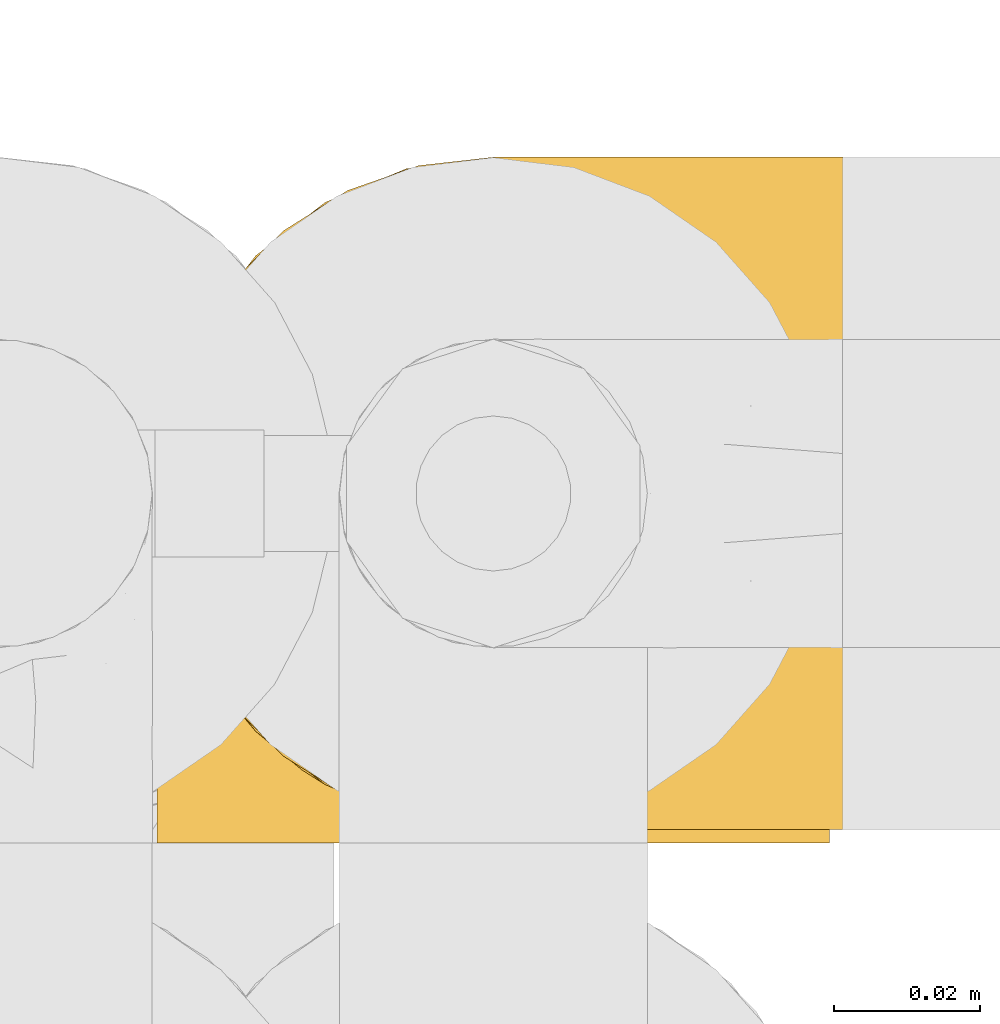
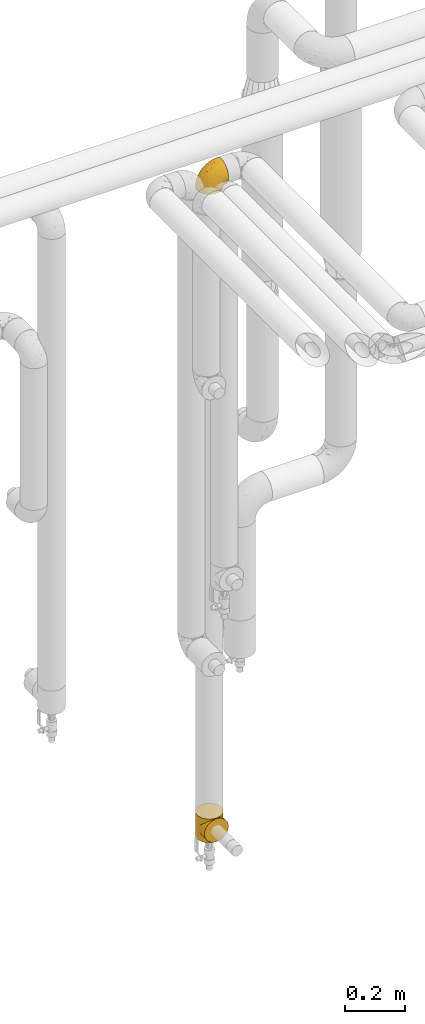
# One storey, part 310 of 827: 2 coverings.
"""IFC2X3 building model written with IfcOpenShell, lengths in millimetres."""

from ifc_helpers import new_model, entity, si_unit, converted_unit, derived_unit, direction, frame, origin, place, context, subcontext, project, spatial, faceted_brep, element, save


model = new_model("IFC2X3")

# Units and contexts
model_context = context("Model", 3, precision=0.01, world=origin(), true_north=direction((6.12303176911189e-17, 1.0)))
body_context = subcontext(model_context, "Body", "Model", "MODEL_VIEW")
ifc_project = project(units=[si_unit("LENGTHUNIT", "METRE", prefix="MILLI"), si_unit("AREAUNIT", "SQUARE_METRE"), si_unit("VOLUMEUNIT", "CUBIC_METRE"), converted_unit("PLANEANGLEUNIT", "DEGREE", entity("IfcRatioMeasure", 0.0174532925199433), si_unit("PLANEANGLEUNIT", "RADIAN"), dimensions=[0, 0, 0, 0, 0, 0, 0]), si_unit("MASSUNIT", "GRAM", prefix="KILO"), derived_unit("MASSDENSITYUNIT", [(si_unit("MASSUNIT", "GRAM", prefix="KILO"), 1), (si_unit("LENGTHUNIT", "METRE"), -3)]), derived_unit("MOMENTOFINERTIAUNIT", [(si_unit("LENGTHUNIT", "METRE"), 4)]), si_unit("TIMEUNIT", "SECOND"), si_unit("FREQUENCYUNIT", "HERTZ"), si_unit("THERMODYNAMICTEMPERATUREUNIT", "DEGREE_CELSIUS"), derived_unit("THERMALTRANSMITTANCEUNIT", [(si_unit("MASSUNIT", "GRAM", prefix="KILO"), 1), (si_unit("THERMODYNAMICTEMPERATUREUNIT", "KELVIN"), -1), (si_unit("TIMEUNIT", "SECOND"), -3)]), derived_unit("VOLUMETRICFLOWRATEUNIT", [(si_unit("LENGTHUNIT", "METRE"), 3), (si_unit("TIMEUNIT", "SECOND"), -1)]), derived_unit("MASSFLOWRATEUNIT", [(si_unit("MASSUNIT", "GRAM", prefix="KILO"), 1), (si_unit("TIMEUNIT", "SECOND"), -1)]), derived_unit("ROTATIONALFREQUENCYUNIT", [(si_unit("TIMEUNIT", "SECOND"), -1)]), si_unit("ELECTRICCURRENTUNIT", "AMPERE"), si_unit("ELECTRICVOLTAGEUNIT", "VOLT"), si_unit("POWERUNIT", "WATT"), si_unit("FORCEUNIT", "NEWTON", prefix="KILO"), si_unit("ILLUMINANCEUNIT", "LUX"), si_unit("LUMINOUSFLUXUNIT", "LUMEN"), si_unit("LUMINOUSINTENSITYUNIT", "CANDELA"), derived_unit("USERDEFINED", [(si_unit("MASSUNIT", "GRAM", prefix="KILO"), -1), (si_unit("LENGTHUNIT", "METRE"), -2), (si_unit("TIMEUNIT", "SECOND"), 3), (si_unit("LUMINOUSFLUXUNIT", "LUMEN"), 1)]), derived_unit("LINEARVELOCITYUNIT", [(si_unit("LENGTHUNIT", "METRE"), 1), (si_unit("TIMEUNIT", "SECOND"), -1)]), si_unit("PRESSUREUNIT", "PASCAL"), derived_unit("USERDEFINED", [(si_unit("LENGTHUNIT", "METRE"), -2), (si_unit("MASSUNIT", "GRAM", prefix="KILO"), 1), (si_unit("TIMEUNIT", "SECOND"), -2)]), derived_unit("LINEARFORCEUNIT", [(si_unit("MASSUNIT", "GRAM", prefix="KILO"), 1), (si_unit("LENGTHUNIT", "METRE"), 1), (si_unit("TIMEUNIT", "SECOND"), -2), (si_unit("LENGTHUNIT", "METRE"), -1)]), derived_unit("PLANARFORCEUNIT", [(si_unit("MASSUNIT", "GRAM", prefix="KILO"), 1), (si_unit("LENGTHUNIT", "METRE"), 1), (si_unit("TIMEUNIT", "SECOND"), -2), (si_unit("LENGTHUNIT", "METRE"), -2)])], contexts=[model_context])

# Site, building, storey
site_placement = place(None, origin())
site = spatial("IfcSite", under=ifc_project, at=site_placement, CompositionType="ELEMENT")
building_placement = place(site_placement, origin())
building = spatial("IfcBuilding", under=site, at=building_placement, CompositionType="ELEMENT")
storey_placement = place(building_placement, frame((0.0, 0.0, 28200.0)))
storey = spatial("IfcBuildingStorey", under=building, at=storey_placement, Name="08", CompositionType="ELEMENT", Elevation=28200.0)

# Coverings
covering_1_placement = place(storey_placement, frame((30677.28, 18393.41, 2950.4)))
element("IfcCovering", 1, at=covering_1_placement, inside=storey, Name=":ADSK_", ObjectType=":ADSK_", PredefinedType="INSULATION", context=body_context, shape_type="Brep", body=[
    faceted_brep([(18.98, 11.68, 1.6), (11.67, 19.0, 1.6), (6.17, 27.76, 1.6), (2.75, 37.52, 1.6), (1.6, 47.8, 1.6), (2.75, 58.08, 1.6), (6.17, 67.85, 1.6), (11.68, 76.61, 1.6), (19.0, 83.92, 1.6), (27.76, 89.42, 1.6), (37.52, 92.84, 1.6), (47.8, 94.0, 1.6), (51.94, 93.53, 1.6), (55.01, 93.18, 1.6), (58.08, 92.84, 1.6), (62.96, 91.13, 1.6), (67.85, 89.42, 1.6), (72.23, 86.66, 1.6), (76.61, 83.91, 1.6), (80.26, 80.25, 1.6), (83.92, 76.59, 1.6), (89.42, 67.83, 1.6), (91.13, 62.95, 1.6), (92.84, 58.07, 1.6), (94.0, 47.8, 1.6), (92.84, 37.51, 1.6), (91.13, 32.63, 1.6), (89.42, 27.74, 1.6), (83.91, 18.98, 1.6), (80.25, 15.33, 1.6), (76.59, 11.67, 1.6), (72.21, 8.92, 1.6), (67.83, 6.17, 1.6), (62.95, 4.46, 1.6), (58.07, 2.75, 1.6), (55.0, 2.41, 1.6), (51.94, 2.06, 1.6), (47.8, 1.6, 1.6), (37.51, 2.75, 1.6), (27.74, 6.17, 1.6), (95.8, 47.8, 3.4), (95.8, 59.75, 4.97), (95.8, 70.9, 9.58), (95.8, 75.68, 13.26), (95.8, 80.46, 16.93), (95.8, 84.13, 21.71), (95.8, 87.81, 26.5), (95.8, 90.11, 32.07), (95.8, 92.42, 37.64), (95.8, 92.9, 41.25), (95.8, 93.17, 43.34), (95.8, 93.45, 45.42), (95.8, 94.0, 49.6), (95.8, 92.42, 61.55), (95.8, 87.81, 72.7), (95.8, 80.46, 82.26), (95.8, 70.9, 89.61), (95.8, 59.75, 94.22), (95.8, 47.8, 95.8), (95.8, 35.84, 94.22), (95.8, 24.7, 89.61), (95.8, 15.13, 82.26), (95.8, 7.78, 72.7), (95.8, 3.17, 61.55), (95.8, 1.6, 49.6), (95.8, 2.14, 45.42), (95.8, 2.69, 41.25), (95.8, 3.17, 37.64), (95.8, 5.48, 32.07), (95.8, 7.78, 26.5), (95.8, 11.46, 21.71), (95.8, 15.13, 16.93), (95.8, 19.91, 13.26), (95.8, 24.7, 9.58), (95.8, 35.84, 4.97), (60.58, 23.61, 81.55), (74.11, 31.99, 90.4), (51.59, 35.87, 83.0), (66.69, 47.8, 91.18), (76.19, 40.43, 93.13), (84.43, 47.8, 94.0), (31.2, 31.83, 66.19), (42.88, 23.37, 70.92), (79.41, 21.41, 85.95), (60.7, 3.07, 49.74), (61.85, 1.6, 35.54), (65.75, 1.6, 38.14), (69.64, 1.6, 40.74), (73.53, 1.6, 43.34), (77.43, 1.6, 45.94), (74.59, 13.45, 77.59), (54.72, 15.25, 71.17), (64.18, 8.07, 65.81), (37.94, 16.0, 59.03), (25.89, 17.34, 45.85), (34.73, 10.58, 45.79), (42.89, 5.34, 41.42), (49.83, 2.39, 34.51), (48.58, 8.36, 56.04), (22.41, 10.04, 15.15), (78.69, 2.59, 56.51), (81.64, 6.28, 68.39), (6.22, 34.28, 23.33), (12.11, 38.73, 42.86), (14.81, 27.25, 39.42), (21.61, 29.88, 53.58), (22.41, 38.6, 59.17), (30.12, 23.44, 59.06), (10.01, 25.25, 22.63), (15.36, 17.23, 20.55), (3.39, 47.8, 12.96), (19.59, 47.8, 56.96), (30.01, 47.8, 67.38), (41.19, 2.53, 18.72), (48.54, 1.6, 5.33), (49.28, 1.6, 9.07), (49.82, 1.6, 11.79), (50.37, 1.6, 14.51), (50.91, 1.6, 17.24), (51.45, 1.6, 19.96), (31.61, 5.71, 21.03), (80.15, 1.6, 46.48), (82.88, 1.6, 47.03), (85.6, 1.6, 47.57), (88.32, 1.6, 48.11), (90.19, 1.6, 48.48), (92.06, 1.6, 48.85), (6.21, 47.8, 30.7), (54.05, 1.6, 23.86), (56.65, 1.6, 27.75), (59.25, 1.6, 31.64), (24.66, 11.89, 31.26), (40.43, 47.8, 77.8), (35.17, 39.69, 72.75), (12.9, 47.8, 43.83), (53.56, 47.8, 84.49), (85.34, 13.84, 14.58), (78.44, 9.16, 16.17), (84.37, 15.79, 10.82), (89.05, 25.75, 4.64), (82.76, 16.09, 7.71), (86.31, 7.51, 25.13), (83.73, 3.99, 32.66), (77.31, 2.66, 34.94), (87.78, 3.16, 36.76), (87.91, 2.35, 40.48), (81.29, 2.23, 39.25), (93.97, 38.35, 3.69), (70.76, 6.18, 13.99), (63.67, 2.7, 21.85), (62.62, 2.93, 17.93), (90.64, 16.01, 15.11), (84.08, 9.08, 21.14), (76.28, 9.3, 12.7), (77.45, 11.68, 7.21), (88.72, 4.65, 32.27), (71.28, 3.65, 25.68), (68.09, 3.61, 22.18), (91.07, 12.8, 18.79), (57.47, 2.43, 10.12), (70.34, 6.83, 9.47), (91.35, 21.65, 10.45), (62.99, 3.7, 11.29), (94.52, 47.8, 2.87), (76.47, 3.37, 31.16), (69.96, 7.03, 6.31), (89.86, 7.87, 25.62), (78.94, 7.26, 21.18), (73.51, 3.41, 28.81), (89.62, 23.81, 7.45), (84.09, 86.5, 21.14), (86.3, 88.08, 25.13), (91.06, 82.79, 18.79), (88.32, 94.0, 48.11), (92.06, 94.0, 48.85), (82.88, 94.0, 47.03), (85.6, 94.0, 47.57), (93.97, 57.24, 3.69), (89.63, 71.76, 7.44), (50.37, 94.0, 14.51), (49.82, 94.0, 11.79), (48.54, 94.0, 5.33), (49.28, 94.0, 9.07), (82.77, 79.49, 7.71), (70.36, 88.75, 9.47), (77.31, 92.93, 34.94), (76.47, 92.22, 31.16), (69.64, 94.0, 40.74), (65.75, 94.0, 38.14), (87.78, 92.43, 36.76), (87.91, 93.24, 40.48), (89.06, 69.82, 4.63), (90.65, 79.57, 15.11), (85.35, 81.74, 14.58), (73.53, 94.0, 43.34), (77.43, 94.0, 45.94), (81.29, 93.36, 39.25), (77.46, 83.9, 7.21), (76.29, 86.28, 12.69), (57.47, 93.16, 10.14), (63.71, 92.88, 21.81), (68.11, 91.98, 22.19), (70.77, 89.41, 14.0), (71.31, 91.93, 25.69), (78.46, 86.42, 16.17), (69.52, 88.82, 6.66), (62.64, 92.66, 17.92), (91.35, 73.93, 10.45), (59.25, 94.0, 31.64), (84.6, 79.5, 10.64), (62.98, 91.89, 11.31), (51.45, 94.0, 19.96), (54.05, 94.0, 23.86), (56.65, 94.0, 27.75), (83.73, 91.6, 32.66), (80.15, 94.0, 46.48), (88.72, 90.94, 32.27), (61.85, 94.0, 35.54), (73.56, 92.16, 28.77), (78.96, 88.32, 21.17), (91.36, 86.13, 23.36), (50.91, 94.0, 17.24), (62.87, 93.2, 47.58), (76.19, 55.16, 93.13), (73.57, 82.02, 77.44), (56.07, 84.29, 66.78), (49.77, 76.94, 71.68), (44.73, 68.33, 74.96), (60.58, 71.98, 81.55), (47.64, 92.52, 36.7), (78.32, 92.9, 56.9), (51.59, 59.72, 83.0), (74.11, 63.6, 90.4), (76.04, 88.89, 67.83), (79.41, 74.18, 85.95), (14.82, 68.35, 39.41), (6.22, 61.33, 23.33), (12.12, 56.86, 42.87), (23.51, 68.62, 53.92), (31.2, 63.76, 66.19), (34.96, 72.19, 64.12), (33.86, 88.69, 33.13), (38.94, 92.19, 23.1), (30.23, 89.75, 16.98), (35.17, 55.9, 72.75), (15.85, 77.99, 23.77), (22.59, 85.21, 18.41), (21.56, 74.99, 43.7), (55.94, 90.23, 54.53), (20.67, 59.86, 55.72), (9.19, 70.75, 17.73), (25.79, 81.72, 38.98), (41.16, 86.53, 50.28), (37.95, 79.6, 59.02)], [[[0, 1, 2, 3, 4, 5, 6, 7, 8, 9, 10, 11, 12, 13, 14, 15, 16, 17, 18, 19, 20, 21, 22, 23, 24, 25, 26, 27, 28, 29, 30, 31, 32, 33, 34, 35, 36, 37, 38, 39]], [[40, 41, 42, 43, 44, 45, 46, 47, 48, 49, 50, 51, 52, 53, 54, 55, 56, 57, 58, 59, 60, 61, 62, 63, 64, 65, 66, 67, 68, 69, 70, 71, 72, 73, 74]], [[75, 76, 77]], [[78, 79, 80]], [[77, 81, 82]], [[76, 75, 83]], [[84, 85, 86, 87, 88, 89]], [[90, 91, 92]], [[76, 60, 59]], [[93, 94, 95]], [[90, 62, 61]], [[83, 61, 60]], [[96, 97, 84]], [[98, 93, 95]], [[0, 39, 99]], [[100, 84, 89]], [[62, 101, 63]], [[2, 102, 3]], [[92, 84, 100]], [[103, 102, 104]], [[103, 105, 106]], [[93, 107, 94]], [[1, 108, 2]], [[92, 101, 90]], [[108, 1, 109]], [[102, 110, 3]], [[93, 82, 107]], [[102, 108, 104]], [[111, 106, 112]], [[109, 0, 99]], [[113, 37, 114, 115, 116, 117, 118, 119]], [[120, 38, 113]], [[100, 89, 121, 122, 123, 124, 125, 126, 64]], [[127, 102, 103]], [[97, 119, 128, 129, 130, 85]], [[99, 120, 131]], [[132, 133, 77]], [[59, 80, 79]], [[1, 0, 109]], [[98, 84, 92]], [[94, 109, 131]], [[120, 39, 38]], [[93, 91, 82]], [[104, 94, 105]], [[97, 113, 119]], [[95, 120, 96]], [[83, 90, 61]], [[91, 93, 98]], [[64, 63, 100]], [[100, 63, 101]], [[77, 76, 79]], [[133, 106, 81]], [[84, 97, 85]], [[113, 96, 120]], [[113, 97, 96]], [[37, 113, 38]], [[110, 102, 127]], [[110, 4, 3]], [[103, 111, 134, 127]], [[90, 75, 91]], [[82, 81, 107]], [[91, 75, 82]], [[77, 82, 75]], [[76, 83, 60]], [[90, 83, 75]], [[105, 107, 81]], [[94, 131, 95]], [[105, 94, 107]], [[109, 94, 104]], [[120, 95, 131]], [[98, 95, 96]], [[84, 98, 96]], [[98, 92, 91]], [[106, 105, 81]], [[103, 104, 105]], [[112, 106, 133]], [[103, 106, 111]], [[112, 133, 132]], [[81, 77, 133]], [[77, 78, 135, 132]], [[120, 99, 39]], [[109, 99, 131]], [[59, 58, 80]], [[59, 79, 76]], [[90, 101, 62]], [[100, 101, 92]], [[2, 108, 102]], [[109, 104, 108]], [[78, 77, 79]], [[136, 137, 138]], [[27, 139, 140]], [[141, 142, 143]], [[144, 145, 121]], [[146, 89, 88]], [[147, 139, 25]], [[148, 149, 150]], [[136, 151, 152]], [[147, 40, 74]], [[24, 147, 25]], [[140, 153, 154]], [[33, 116, 34]], [[73, 72, 151]], [[114, 37, 36, 35, 34, 116, 115]], [[146, 155, 144]], [[156, 85, 130]], [[157, 149, 148]], [[151, 158, 152]], [[117, 33, 159]], [[29, 154, 160]], [[161, 74, 73]], [[162, 128, 119]], [[66, 65, 64, 126, 125, 124, 123, 122, 67]], [[163, 147, 24]], [[27, 140, 28]], [[149, 129, 150]], [[139, 27, 26, 25]], [[68, 144, 69]], [[129, 128, 150]], [[164, 87, 86]], [[130, 129, 149]], [[122, 145, 67]], [[154, 153, 148]], [[162, 119, 159]], [[165, 30, 160]], [[150, 160, 148]], [[128, 162, 150]], [[30, 165, 31]], [[145, 144, 68]], [[89, 146, 144]], [[87, 164, 143]], [[166, 155, 142]], [[88, 87, 143]], [[162, 160, 150]], [[160, 30, 29]], [[154, 29, 28]], [[140, 154, 28]], [[160, 154, 148]], [[140, 137, 153]], [[157, 148, 153]], [[156, 130, 157]], [[153, 137, 157]], [[157, 137, 156]], [[167, 137, 136]], [[168, 85, 156]], [[152, 168, 167]], [[167, 168, 156]], [[164, 152, 141]], [[71, 158, 72]], [[152, 167, 136]], [[88, 142, 146]], [[144, 155, 69]], [[146, 142, 155]], [[70, 166, 71]], [[142, 141, 166]], [[70, 69, 155]], [[141, 158, 71]], [[161, 73, 151]], [[138, 137, 140]], [[161, 136, 169]], [[136, 161, 151]], [[74, 161, 169]], [[152, 158, 141]], [[151, 72, 158]], [[168, 152, 164]], [[137, 167, 156]], [[164, 86, 168]], [[85, 168, 86]], [[116, 33, 117]], [[130, 149, 157]], [[67, 145, 68]], [[121, 89, 144]], [[145, 122, 121]], [[40, 147, 163]], [[169, 147, 74]], [[159, 33, 32]], [[162, 159, 32]], [[159, 119, 118, 117]], [[139, 147, 169]], [[139, 169, 138]], [[162, 32, 31]], [[141, 143, 164]], [[88, 143, 142]], [[71, 166, 141]], [[155, 166, 70]], [[139, 138, 140]], [[169, 136, 138]], [[160, 162, 165]], [[162, 31, 165]], [[170, 171, 172]], [[173, 174, 52, 51, 50, 49, 48, 175, 176]], [[177, 178, 41]], [[179, 15, 180]], [[12, 11, 181, 182, 180, 14, 13]], [[183, 21, 20]], [[19, 18, 184]], [[185, 186, 187]], [[186, 188, 187]], [[43, 172, 44]], [[189, 190, 47]], [[23, 22, 21, 191]], [[170, 192, 193]], [[40, 163, 177]], [[194, 195, 196]], [[24, 23, 177]], [[197, 198, 183]], [[199, 15, 179]], [[47, 46, 189]], [[200, 201, 202]], [[201, 203, 204]], [[205, 206, 184]], [[207, 41, 178]], [[16, 15, 199]], [[14, 180, 15]], [[202, 201, 198]], [[208, 201, 200]], [[163, 24, 177]], [[48, 47, 190]], [[196, 195, 189]], [[197, 184, 202]], [[204, 193, 209]], [[210, 211, 212]], [[206, 212, 213]], [[205, 17, 210]], [[184, 206, 202]], [[210, 212, 206]], [[185, 194, 214]], [[189, 215, 190]], [[216, 45, 214]], [[186, 171, 170]], [[189, 216, 196]], [[197, 20, 19]], [[194, 185, 187]], [[197, 183, 20]], [[184, 197, 19]], [[197, 202, 198]], [[206, 200, 202]], [[204, 183, 198]], [[201, 208, 203]], [[203, 208, 217]], [[204, 198, 201]], [[217, 188, 218]], [[193, 219, 170]], [[171, 186, 185]], [[170, 218, 186]], [[170, 219, 218]], [[42, 207, 192]], [[171, 220, 172]], [[216, 189, 46]], [[214, 194, 196]], [[44, 220, 45]], [[214, 196, 216]], [[216, 46, 45]], [[214, 45, 220]], [[192, 43, 42]], [[204, 203, 219]], [[207, 193, 192]], [[209, 193, 178]], [[41, 207, 42]], [[193, 207, 178]], [[43, 192, 172]], [[170, 172, 192]], [[204, 219, 193]], [[219, 203, 218]], [[217, 218, 203]], [[188, 186, 218]], [[206, 213, 200]], [[208, 200, 213]], [[199, 210, 16]], [[215, 189, 195]], [[215, 175, 190]], [[175, 48, 190]], [[199, 179, 221, 211]], [[210, 199, 211]], [[23, 191, 177]], [[40, 177, 41]], [[178, 177, 191]], [[21, 183, 191]], [[209, 191, 183]], [[205, 18, 17]], [[17, 16, 210]], [[171, 185, 214]], [[172, 220, 44]], [[214, 220, 171]], [[191, 209, 178]], [[204, 209, 183]], [[206, 205, 210]], [[18, 205, 184]], [[222, 195, 194, 187, 188, 217]], [[57, 223, 80]], [[224, 225, 226]], [[226, 227, 228]], [[229, 217, 208, 213, 212, 211]], [[230, 52, 174, 173, 176, 175, 215, 195]], [[231, 232, 228]], [[231, 78, 223]], [[223, 57, 232]], [[224, 233, 225]], [[233, 54, 53]], [[234, 232, 56]], [[56, 55, 234]], [[234, 224, 228]], [[235, 236, 237]], [[224, 55, 54]], [[238, 239, 240]], [[52, 230, 53]], [[241, 242, 243]], [[227, 244, 231]], [[11, 10, 242]], [[236, 6, 5]], [[7, 245, 8]], [[8, 246, 9]], [[238, 247, 235]], [[222, 229, 248]], [[242, 211, 221, 179, 180, 182, 181, 11]], [[233, 53, 230]], [[111, 112, 249]], [[250, 6, 236]], [[246, 251, 241]], [[6, 250, 7]], [[127, 236, 110]], [[248, 229, 252]], [[246, 8, 245]], [[235, 245, 250]], [[236, 5, 110]], [[235, 249, 238]], [[237, 236, 127]], [[243, 9, 246]], [[252, 229, 241]], [[56, 232, 57]], [[222, 230, 195]], [[225, 248, 252]], [[248, 233, 230]], [[54, 233, 224]], [[231, 228, 227]], [[244, 132, 231]], [[248, 225, 233]], [[226, 225, 253]], [[235, 250, 236]], [[245, 7, 250]], [[251, 246, 245]], [[243, 246, 241]], [[247, 245, 235]], [[252, 251, 253]], [[229, 222, 217]], [[230, 222, 248]], [[5, 4, 110]], [[237, 127, 134, 111]], [[238, 249, 239]], [[224, 234, 55]], [[232, 234, 228]], [[242, 241, 229]], [[10, 9, 243]], [[211, 242, 229]], [[10, 243, 242]], [[80, 223, 78]], [[80, 58, 57]], [[231, 223, 232]], [[227, 240, 239]], [[224, 226, 228]], [[240, 226, 253]], [[227, 239, 244]], [[226, 240, 227]], [[251, 247, 253]], [[240, 253, 247]], [[249, 235, 237]], [[237, 111, 249]], [[112, 132, 244]], [[112, 244, 249]], [[78, 231, 132, 135]], [[249, 244, 239]], [[247, 238, 240]], [[245, 247, 251]], [[251, 252, 241]], [[225, 252, 253]]]),
])
covering_2_placement = place(storey_placement, frame((30677.28, 18393.2, 327.0)))
element("IfcCovering", 2, at=covering_2_placement, inside=storey, Name=":ADSK_", ObjectType=":ADSK_", PredefinedType="INSULATION", context=body_context, shape_type="Brep", body=[
    faceted_brep([(2.11, 41.09, 41.09), (1.6, 48.0, 0.0), (3.17, 36.04, 0.0), (25.36, 7.85, 7.85), (27.48, 6.84, 0.0), (29.21, 5.7, 5.7), (7.78, 24.9, 0.0), (6.34, 27.6, 27.6), (10.15, 21.22, 21.22), (15.13, 15.33, 0.0), (24.7, 7.99, 0.0), (35.84, 3.37, 0.0), (37.01, 3.18, 3.18), (35.9, 3.54, 3.54), (33.67, 4.26, 4.26), (1.6, 48.0, 48.0), (2.11, 41.09, 54.91), (1.6, 48.0, 96.0), (38.13, 2.82, 2.82), (37.33, 3.18, 0.0), (38.83, 2.98, 0.0), (3.68, 34.26, 34.26), (44.06, 2.29, 0.0), (44.81, 2.19, 0.0), (44.17, 2.18, 2.18), (43.31, 2.39, 0.0), (21.52, 10.0, 10.0), (19.91, 11.66, 0.0), (33.05, 4.53, 0.0), (31.44, 4.98, 4.98), (30.27, 5.68, 0.0), (46.3, 2.0, 0.0), (46.59, 1.93, 1.93), (45.38, 2.06, 2.06), (42.96, 2.31, 2.31), (40.32, 2.78, 0.0), (41.82, 2.59, 0.0), (40.54, 2.57, 2.57), (15.18, 15.28, 15.28), (39.33, 2.7, 2.7), (41.75, 2.44, 2.44), (47.8, 1.8, 0.0), (47.8, 1.8, 1.8), (47.8, 1.8, 96.0), (46.59, 1.93, 94.07), (47.8, 1.8, 94.2), (45.55, 2.1, 0.0), (61.93, 4.27, 4.27), (59.75, 3.37, 0.0), (62.54, 4.53, 0.0), (52.28, 2.39, 0.0), (53.77, 2.59, 0.0), (52.64, 2.31, 2.31), (59.7, 3.55, 3.55), (58.59, 3.19, 3.19), (65.32, 5.68, 0.0), (66.38, 5.7, 5.7), (64.16, 4.98, 4.98), (57.48, 2.83, 2.83), (56.76, 2.98, 0.0), (58.26, 3.18, 0.0), (68.11, 6.84, 0.0), (70.9, 7.99, 0.0), (70.23, 7.85, 7.85), (74.07, 10.0, 10.0), (75.68, 11.66, 0.0), (80.41, 15.27, 15.27), (50.22, 2.06, 2.06), (49.29, 2.0, 0.0), (50.04, 2.1, 0.0), (50.78, 2.19, 0.0), (80.46, 15.33, 0.0), (85.44, 21.21, 21.21), (87.81, 24.9, 0.0), (55.06, 2.57, 2.57), (53.85, 2.44, 2.44), (89.25, 27.6, 27.6), (92.42, 36.04, 0.0), (56.27, 2.7, 2.7), (55.27, 2.78, 0.0), (93.48, 41.09, 41.09), (94.0, 48.0, 0.0), (91.9, 34.26, 34.26), (94.0, 48.0, 48.0), (93.48, 41.09, 54.91), (94.0, 48.0, 96.0), (49.01, 1.93, 1.93), (51.43, 2.18, 2.18), (51.53, 2.29, 0.0), (49.01, 1.93, 94.07), (70.9, 88.01, 96.0), (59.75, 92.63, 96.0), (47.8, 94.2, 96.0), (35.84, 92.63, 96.0), (24.7, 88.01, 96.0), (15.13, 80.67, 96.0), (7.78, 71.1, 96.0), (3.17, 59.96, 96.0), (3.17, 36.04, 96.0), (7.78, 24.9, 96.0), (15.13, 15.33, 96.0), (19.91, 11.66, 96.0), (24.7, 7.99, 96.0), (27.48, 6.84, 96.0), (30.27, 5.68, 96.0), (33.05, 4.53, 96.0), (35.84, 3.37, 96.0), (37.33, 3.18, 96.0), (38.83, 2.98, 96.0), (40.32, 2.78, 96.0), (41.82, 2.59, 96.0), (43.31, 2.39, 96.0), (44.06, 2.29, 96.0), (44.81, 2.19, 96.0), (45.55, 2.1, 96.0), (46.3, 2.0, 96.0), (49.29, 2.0, 96.0), (50.04, 2.1, 96.0), (50.78, 2.19, 96.0), (51.53, 2.29, 96.0), (52.28, 2.39, 96.0), (53.77, 2.59, 96.0), (55.27, 2.78, 96.0), (56.76, 2.98, 96.0), (58.26, 3.18, 96.0), (59.75, 3.37, 96.0), (62.54, 4.53, 96.0), (65.32, 5.68, 96.0), (68.11, 6.84, 96.0), (70.9, 7.99, 96.0), (75.68, 11.66, 96.0), (80.46, 15.33, 96.0), (87.81, 24.9, 96.0), (92.42, 36.04, 96.0), (92.42, 59.96, 96.0), (87.81, 71.1, 96.0), (80.46, 80.67, 96.0), (3.17, 59.96, 0.0), (7.78, 71.1, 0.0), (15.13, 80.67, 0.0), (24.7, 88.01, 0.0), (35.84, 92.63, 0.0), (47.8, 94.2, 0.0), (59.75, 92.63, 0.0), (70.9, 88.01, 0.0), (80.46, 80.67, 0.0), (87.81, 71.1, 0.0), (92.42, 59.96, 0.0), (33.67, 4.26, 91.74), (35.9, 3.54, 92.46), (37.01, 3.18, 92.82), (3.68, 34.26, 61.74), (6.34, 27.6, 68.4), (29.21, 5.7, 90.3), (39.33, 2.7, 93.3), (40.54, 2.57, 93.43), (10.15, 21.22, 74.78), (21.52, 10.0, 86.0), (25.36, 7.85, 88.15), (15.18, 15.28, 80.72), (31.44, 4.98, 91.02), (38.13, 2.82, 93.18), (45.38, 2.06, 93.94), (41.75, 2.44, 93.56), (42.96, 2.31, 93.69), (44.17, 2.18, 93.82), (66.38, 5.7, 90.3), (64.16, 4.98, 91.02), (74.07, 10.0, 86.0), (55.06, 2.57, 93.43), (80.41, 15.27, 80.73), (70.23, 7.85, 88.15), (56.27, 2.7, 93.3), (57.48, 2.83, 93.17), (51.43, 2.18, 93.82), (52.64, 2.31, 93.69), (61.93, 4.27, 91.73), (58.59, 3.19, 92.81), (59.7, 3.55, 92.45), (89.25, 27.6, 68.4), (91.9, 34.26, 61.74), (85.44, 21.21, 74.79), (53.85, 2.44, 93.56), (50.22, 2.06, 93.94), (1.6, 0.0, 48.0), (3.17, 0.0, 36.04), (7.78, 0.0, 24.9), (15.13, 0.0, 15.33), (19.91, 0.0, 11.66), (24.7, 0.0, 7.99), (27.48, 0.0, 6.84), (30.27, 0.0, 5.68), (33.05, 0.0, 4.53), (35.84, 0.0, 3.37), (37.33, 0.0, 3.18), (38.83, 0.0, 2.98), (40.32, 0.0, 2.78), (41.82, 0.0, 2.59), (43.31, 0.0, 2.39), (44.06, 0.0, 2.29), (44.81, 0.0, 2.19), (45.55, 0.0, 2.1), (46.3, 0.0, 2.0), (47.8, 0.0, 1.8), (49.29, 0.0, 2.0), (50.04, 0.0, 2.1), (50.78, 0.0, 2.19), (51.53, 0.0, 2.29), (52.28, 0.0, 2.39), (53.77, 0.0, 2.59), (55.27, 0.0, 2.78), (56.76, 0.0, 2.98), (58.26, 0.0, 3.18), (59.75, 0.0, 3.37), (62.54, 0.0, 4.53), (65.32, 0.0, 5.68), (68.11, 0.0, 6.84), (70.9, 0.0, 7.99), (75.68, 0.0, 11.66), (80.46, 0.0, 15.33), (87.81, 0.0, 24.9), (92.42, 0.0, 36.04), (94.0, 0.0, 48.0), (92.42, 0.0, 59.96), (87.81, 0.0, 71.1), (80.46, 0.0, 80.67), (75.68, 0.0, 84.34), (70.9, 0.0, 88.01), (68.11, 0.0, 89.16), (65.32, 0.0, 90.32), (62.54, 0.0, 91.47), (59.75, 0.0, 92.63), (58.26, 0.0, 92.82), (56.76, 0.0, 93.02), (55.27, 0.0, 93.22), (53.77, 0.0, 93.41), (52.28, 0.0, 93.61), (51.53, 0.0, 93.71), (50.78, 0.0, 93.81), (50.04, 0.0, 93.9), (49.29, 0.0, 94.0), (47.8, 0.0, 94.2), (46.3, 0.0, 94.0), (45.55, 0.0, 93.9), (44.81, 0.0, 93.81), (44.06, 0.0, 93.71), (43.31, 0.0, 93.61), (41.82, 0.0, 93.41), (40.32, 0.0, 93.22), (38.83, 0.0, 93.02), (37.33, 0.0, 92.82), (35.84, 0.0, 92.63), (33.05, 0.0, 91.47), (30.27, 0.0, 90.32), (27.48, 0.0, 89.16), (24.7, 0.0, 88.01), (19.91, 0.0, 84.34), (15.13, 0.0, 80.67), (7.78, 0.0, 71.1), (3.17, 0.0, 59.96)], [[[0, 1, 2]], [[3, 4, 5]], [[2, 6, 7]], [[8, 6, 9]], [[4, 3, 10]], [[8, 7, 6]], [[11, 12, 13, 14]], [[0, 15, 1]], [[15, 16, 17]], [[18, 19, 20]], [[7, 21, 2]], [[0, 2, 21]], [[19, 18, 12]], [[12, 11, 19]], [[22, 23, 24, 25]], [[26, 27, 10]], [[28, 29, 30]], [[28, 11, 14]], [[31, 32, 33]], [[29, 28, 14]], [[34, 25, 24]], [[35, 36, 37]], [[38, 9, 27]], [[38, 27, 26]], [[5, 30, 29]], [[20, 39, 18]], [[5, 4, 30]], [[26, 10, 3]], [[35, 39, 20]], [[9, 38, 8]], [[36, 34, 40, 37]], [[34, 36, 25]], [[39, 35, 37]], [[32, 41, 42]], [[43, 44, 45]], [[23, 33, 24]], [[33, 23, 46, 31]], [[41, 32, 31]], [[47, 48, 49]], [[50, 51, 52]], [[48, 47, 53, 54]], [[55, 56, 57]], [[58, 59, 60]], [[61, 62, 63]], [[49, 57, 47]], [[58, 60, 54]], [[64, 62, 65]], [[66, 64, 65]], [[61, 63, 56]], [[67, 68, 69, 70]], [[65, 71, 66]], [[62, 64, 63]], [[72, 71, 73]], [[51, 74, 75, 52]], [[76, 73, 77]], [[78, 79, 59]], [[59, 58, 78]], [[80, 77, 81]], [[79, 78, 74]], [[76, 72, 73]], [[80, 82, 77]], [[83, 80, 81]], [[84, 83, 85]], [[56, 55, 61]], [[76, 77, 82]], [[57, 49, 55]], [[48, 54, 60]], [[71, 72, 66]], [[74, 51, 79]], [[86, 41, 68]], [[87, 50, 52]], [[70, 87, 67]], [[50, 87, 70, 88]], [[41, 86, 42]], [[89, 43, 45]], [[68, 67, 86]], [[90, 91, 92, 93, 94, 95, 96, 97, 17, 98, 99, 100, 101, 102, 103, 104, 105, 106, 107, 108, 109, 110, 111, 112, 113, 114, 115, 43, 116, 117, 118, 119, 120, 121, 122, 123, 124, 125, 126, 127, 128, 129, 130, 131, 132, 133, 85, 134, 135, 136]], [[1, 137, 138, 139, 140, 141, 142, 143, 144, 145, 146, 147, 81, 77, 73, 71, 65, 62, 61, 55, 49, 48, 60, 59, 79, 51, 50, 88, 70, 69, 68, 41, 31, 46, 23, 22, 25, 36, 35, 20, 19, 11, 28, 30, 4, 10, 27, 9, 6, 2]], [[140, 139, 95, 94]], [[92, 142, 141, 93]], [[141, 140, 94, 93]], [[96, 138, 137, 97]], [[1, 15, 17, 97, 137]], [[95, 139, 138, 96]], [[106, 148, 149, 150]], [[151, 152, 98]], [[153, 104, 103]], [[148, 106, 105]], [[16, 151, 98]], [[109, 154, 155]], [[17, 16, 98]], [[99, 156, 100]], [[99, 98, 152]], [[156, 99, 152]], [[102, 157, 158]], [[106, 150, 107]], [[155, 110, 109]], [[157, 101, 159]], [[105, 160, 148]], [[161, 107, 150]], [[162, 115, 114, 113]], [[157, 102, 101]], [[153, 103, 158]], [[104, 153, 160]], [[159, 101, 100]], [[102, 158, 103]], [[108, 161, 154]], [[110, 155, 163, 164]], [[164, 111, 110]], [[161, 108, 107]], [[160, 105, 104]], [[159, 100, 156]], [[154, 109, 108]], [[44, 43, 115]], [[165, 111, 164]], [[113, 165, 162]], [[111, 165, 113, 112]], [[115, 162, 44]], [[166, 127, 167]], [[166, 128, 127]], [[129, 168, 130]], [[122, 121, 169]], [[170, 130, 168]], [[171, 168, 129]], [[123, 172, 173]], [[119, 118, 174, 120]], [[128, 171, 129]], [[174, 175, 120]], [[126, 125, 176]], [[171, 128, 166]], [[170, 131, 130]], [[125, 177, 178, 176]], [[179, 180, 133]], [[173, 124, 123]], [[177, 125, 124]], [[180, 84, 133]], [[131, 181, 132]], [[181, 131, 170]], [[179, 132, 181]], [[179, 133, 132]], [[121, 175, 182, 169]], [[167, 126, 176]], [[84, 85, 133]], [[126, 167, 127]], [[122, 172, 123]], [[124, 173, 177]], [[116, 89, 183]], [[175, 121, 120]], [[172, 122, 169]], [[118, 183, 174]], [[183, 118, 117, 116]], [[43, 89, 116]], [[83, 81, 147, 134, 85]], [[134, 147, 146, 135]], [[146, 145, 136, 135]], [[136, 145, 144, 90]], [[90, 144, 143, 91]], [[91, 143, 142, 92]], [[184, 185, 186, 187, 188, 189, 190, 191, 192, 193, 194, 195, 196, 197, 198, 199, 200, 201, 202, 203, 204, 205, 206, 207, 208, 209, 210, 211, 212, 213, 214, 215, 216, 217, 218, 219, 220, 221, 222, 223, 224, 225, 226, 227, 228, 229, 230, 231, 232, 233, 234, 235, 236, 237, 238, 239, 240, 241, 242, 243, 244, 245, 246, 247, 248, 249, 250, 251, 252, 253, 254, 255, 256, 257, 258, 259]], [[39, 196, 195]], [[198, 197, 34]], [[193, 14, 13, 12]], [[5, 191, 190]], [[14, 193, 192]], [[190, 189, 3]], [[192, 29, 14]], [[18, 194, 12]], [[26, 189, 188]], [[38, 26, 188]], [[190, 3, 5]], [[33, 202, 201, 200]], [[188, 187, 38]], [[189, 26, 3]], [[8, 187, 186]], [[29, 192, 191]], [[7, 186, 185]], [[193, 12, 194]], [[0, 185, 184]], [[191, 5, 29]], [[7, 8, 186]], [[197, 37, 40, 34]], [[0, 21, 185]], [[15, 0, 184]], [[18, 195, 194]], [[7, 185, 21]], [[196, 39, 37]], [[187, 8, 38]], [[37, 197, 196]], [[195, 18, 39]], [[32, 203, 202]], [[24, 198, 34]], [[200, 24, 33]], [[198, 24, 200, 199]], [[203, 32, 42]], [[202, 33, 32]], [[16, 184, 259]], [[158, 254, 153]], [[259, 258, 152]], [[156, 258, 257]], [[254, 158, 255]], [[156, 152, 258]], [[251, 150, 149, 148]], [[16, 15, 184]], [[161, 250, 249]], [[152, 151, 259]], [[16, 259, 151]], [[250, 161, 150]], [[150, 251, 250]], [[245, 244, 165, 246]], [[157, 256, 255]], [[252, 160, 253]], [[252, 251, 148]], [[242, 44, 162]], [[160, 252, 148]], [[164, 246, 165]], [[248, 247, 155]], [[159, 257, 256]], [[159, 256, 157]], [[153, 253, 160]], [[249, 154, 161]], [[153, 254, 253]], [[157, 255, 158]], [[248, 154, 249]], [[257, 159, 156]], [[247, 164, 163, 155]], [[164, 247, 246]], [[154, 248, 155]], [[44, 241, 45]], [[244, 162, 165]], [[162, 244, 243, 242]], [[241, 44, 242]], [[176, 231, 230]], [[236, 235, 175]], [[231, 176, 178, 177]], [[229, 166, 167]], [[173, 233, 232]], [[228, 227, 171]], [[230, 167, 176]], [[173, 232, 177]], [[168, 227, 226]], [[170, 168, 226]], [[228, 171, 166]], [[183, 240, 239, 238]], [[226, 225, 170]], [[227, 168, 171]], [[181, 225, 224]], [[235, 169, 182, 175]], [[179, 224, 223]], [[172, 234, 233]], [[233, 173, 172]], [[84, 223, 222]], [[234, 172, 169]], [[179, 181, 224]], [[84, 180, 223]], [[83, 84, 222]], [[166, 229, 228]], [[179, 223, 180]], [[167, 230, 229]], [[231, 177, 232]], [[225, 181, 170]], [[169, 235, 234]], [[89, 241, 240]], [[174, 236, 175]], [[238, 174, 183]], [[236, 174, 238, 237]], [[241, 89, 45]], [[240, 183, 89]], [[80, 222, 221]], [[209, 52, 75, 74]], [[221, 220, 76]], [[72, 220, 219]], [[210, 78, 211]], [[72, 76, 220]], [[63, 216, 56]], [[80, 83, 222]], [[54, 213, 212]], [[76, 82, 221]], [[80, 221, 82]], [[58, 212, 211]], [[216, 63, 217]], [[207, 206, 87, 208]], [[64, 218, 217]], [[204, 86, 67]], [[214, 213, 47]], [[57, 214, 47]], [[212, 58, 54]], [[52, 208, 87]], [[210, 209, 74]], [[66, 219, 218]], [[66, 218, 64]], [[56, 215, 57]], [[211, 78, 58]], [[56, 216, 215]], [[64, 217, 63]], [[213, 54, 53, 47]], [[219, 66, 72]], [[214, 57, 215]], [[52, 209, 208]], [[78, 210, 74]], [[86, 203, 42]], [[206, 67, 87]], [[67, 206, 205, 204]], [[203, 86, 204]]]),
])

save(model, "model.ifc")
